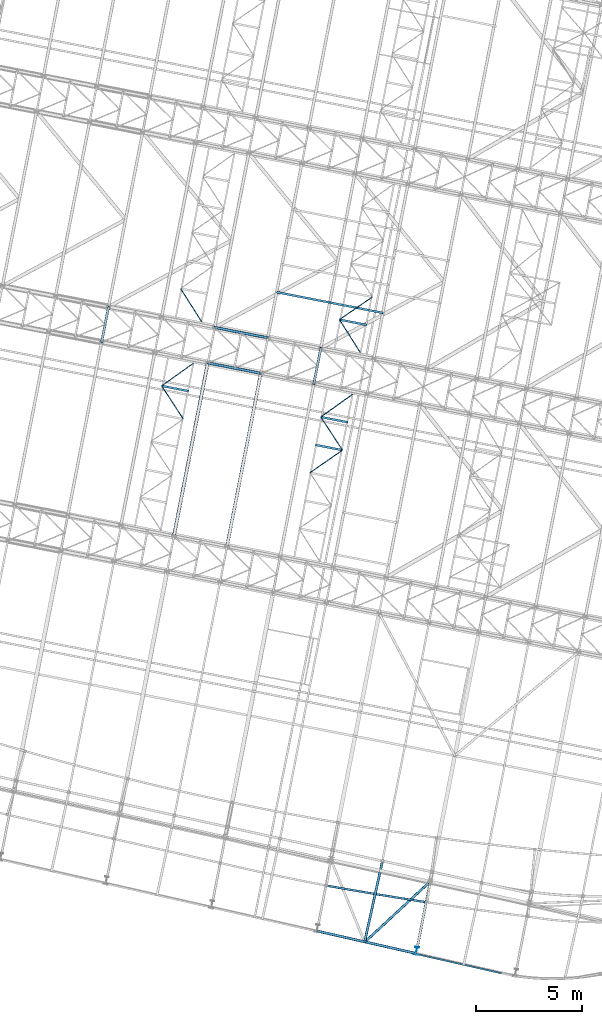
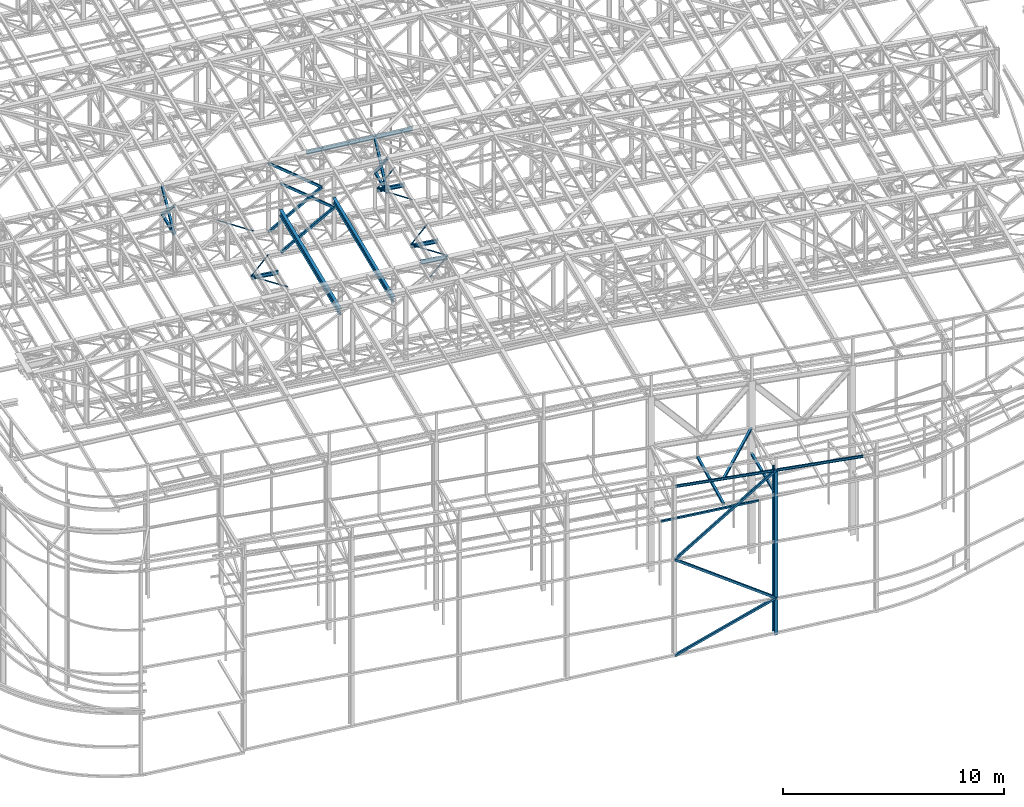
# One storey, part 45 of 215: 24 beams, 11 members, 35 elements without a shape of their own.
"""IFC2X3 building model written with IfcOpenShell, lengths in millimetres."""

import ifcopenshell
import ifcopenshell.guid

model = None  # the IFC model being written
_history = None  # IfcOwnerHistory: only IFC2X3 demands one
_inside = {}  # id of a spatial element -> (the spatial element, [elements in it])
_under = {}  # id of a project, library or spatial element -> (it, [spatial elements below it])
_declared = {}  # id of a project -> (the project, [libraries it declares])
_typed = {}  # id of a type object -> (the type object, [elements of that type])
_made_of = {}  # id of a material, layer set ... -> (it, [elements and type objects made of it])


def new_model(schema):
    """Start an empty IFC model of exactly this schema.

    Asked for "IFC4X3", IfcOpenShell would pick the latest addendum, in which some entities
    have other attributes; the version numbers below select the first issue.
    IFC2X3 requires an IfcOwnerHistory on every rooted entity: one is made here for all.
    """
    global model, _history
    if schema == "IFC4X3":
        model = ifcopenshell.file(schema_version=(4, 3, 0, 0))
    else:
        model = ifcopenshell.file(schema=schema)
    _inside.clear()
    _under.clear()
    _declared.clear()
    _typed.clear()
    _made_of.clear()
    _history = None
    if model.schema == "IFC2X3":
        org = make("IfcOrganization", Name="unknown")
        user = make(
            "IfcPersonAndOrganization",
            ThePerson=make("IfcPerson", FamilyName="unknown"),
            TheOrganization=org,
        )
        app = make(
            "IfcApplication",
            ApplicationDeveloper=org,
            Version="unknown",
            ApplicationFullName="unknown",
            ApplicationIdentifier="unknown",
        )
        _history = make(
            "IfcOwnerHistory",
            OwningUser=user,
            OwningApplication=app,
            ChangeAction="ADDED",
            CreationDate=0,
        )
    return model


def make(cls, **values):
    """One entity of the class cls with the attributes given. An attribute that is None is left unset."""
    return model.create_entity(
        cls, **{name: value for name, value in values.items() if value is not None}
    )


def entity(cls, *values):
    """Any entity or typed value of the class cls, its attributes in the order of the schema. None: left unset."""
    e = model.create_entity(cls)
    for i, value in enumerate(values):
        if value is not None:
            e[i] = value
    return e


def rooted(cls, **values):
    """An entity with a GlobalId (a new one), such as an element, a storey or a relation."""
    return make(cls, GlobalId=ifcopenshell.guid.new(), OwnerHistory=_history, **values)


def si_unit(unit_type, name, prefix=None):
    """IfcSIUnit, for example si_unit("LENGTHUNIT", "METRE", prefix="MILLI")."""
    return make("IfcSIUnit", UnitType=unit_type, Prefix=prefix, Name=name)


def assignment(units):
    """IfcUnitAssignment: the units of a project."""
    return None if units is None else make("IfcUnitAssignment", Units=units)


def point(xyz):
    """IfcCartesianPoint."""
    return None if xyz is None else make("IfcCartesianPoint", Coordinates=xyz)


def direction(xyz):
    """IfcDirection."""
    return None if xyz is None else make("IfcDirection", DirectionRatios=xyz)


def frame(location, z_axis=None, x_axis=None):
    """IfcAxis2Placement3D, a coordinate frame: its origin and axes. An axis left out is left unset."""
    return make(
        "IfcAxis2Placement3D",
        Location=point(location),
        Axis=direction(z_axis),
        RefDirection=direction(x_axis),
    )


def frame_2d(location, x_axis=None):
    """IfcAxis2Placement2D, a coordinate frame in the plane: its origin and x axis."""
    return make(
        "IfcAxis2Placement2D", Location=point(location), RefDirection=direction(x_axis)
    )


def origin_with_axes():
    """The frame at (0, 0, 0) with the z axis (0, 0, 1) and the x axis (1, 0, 0) written out."""
    return frame((0.0, 0.0, 0.0), z_axis=(0.0, 0.0, 1.0), x_axis=(1.0, 0.0, 0.0))


def origin_2d_with_axis():
    """The frame at (0, 0) in the plane with the x axis (1, 0) written out."""
    return frame_2d((0.0, 0.0), x_axis=(1.0, 0.0))


def place(relative_to, where):
    """IfcLocalPlacement: puts the frame where relative to a parent placement (None: the world)."""
    return make(
        "IfcLocalPlacement", PlacementRelTo=relative_to, RelativePlacement=where
    )


def context(
    kind, dimensions, precision=None, world=None, true_north=None, identifier=None
):
    """IfcGeometricRepresentationContext, for example the 3D "Model" context."""
    return make(
        "IfcGeometricRepresentationContext",
        ContextIdentifier=identifier,
        ContextType=kind,
        CoordinateSpaceDimension=dimensions,
        Precision=precision,
        WorldCoordinateSystem=world,
        TrueNorth=true_north,
    )


def subcontext(parent, identifier, kind, view, scale=None):
    """IfcGeometricRepresentationSubContext, for example "Body" below "Model"."""
    return make(
        "IfcGeometricRepresentationSubContext",
        ContextIdentifier=identifier,
        ContextType=kind,
        ParentContext=parent,
        TargetScale=scale,
        TargetView=view,
    )


def project(units=None, contexts=None):
    """IfcProject with its units and contexts."""
    return rooted(
        "IfcProject",
        Name="project",
        RepresentationContexts=contexts,
        UnitsInContext=assignment(units),
    )


def spatial(cls, under=None, at=None, **own):
    """A site, building, storey or space (cls), placed at a placement, below another one or the project."""
    s = rooted(cls, ObjectPlacement=at, **own)
    if under is not None:
        _under.setdefault(under.id(), (under, []))[1].append(s)
    return s


def profile(cls, at=None, kind="AREA", **sizes):
    """A parametric profile (cls). Its sizes go by their IFC names, for example OverallWidth=200.0."""
    return make(cls, ProfileType=kind, Position=at, **sizes)


def hollow_rectangle(**sizes):
    """IfcRectangleHollowProfileDef."""
    return profile("IfcRectangleHollowProfileDef", **sizes)


def i_section(**sizes):
    """IfcIShapeProfileDef."""
    return profile("IfcIShapeProfileDef", **sizes)


def extrude(swept, where, along, depth):
    """IfcExtrudedAreaSolid: the profile swept, set in the frame where, extruded along a direction by depth."""
    return make(
        "IfcExtrudedAreaSolid",
        SweptArea=swept,
        Position=where,
        ExtrudedDirection=direction(along),
        Depth=depth,
    )


def clip(a, b, op="DIFFERENCE"):
    """IfcBooleanClippingResult: the solid a cut by the half space b."""
    return make(
        "IfcBooleanClippingResult", Operator=op, FirstOperand=a, SecondOperand=b
    )


def halfspace(plane, agree):
    """IfcHalfSpaceSolid: all space on one side of the plane z = 0 of the frame plane."""
    return make(
        "IfcHalfSpaceSolid",
        BaseSurface=make("IfcPlane", Position=plane),
        AgreementFlag=agree,
    )


def shape(context_of_items, identifier, shape_type, items):
    """IfcShapeRepresentation: the items that make up one representation, for example the "Body"."""
    return make(
        "IfcShapeRepresentation",
        ContextOfItems=context_of_items,
        RepresentationIdentifier=identifier,
        RepresentationType=shape_type,
        Items=items,
    )


def material(Name=None, Category=None):
    """IfcMaterial."""
    return make("IfcMaterial", Name=Name, Category=Category)


def made_of(thing, what):
    """Note that an element or type object is made of a material, layer set ...; save() writes the relation."""
    if what is not None:
        _made_of.setdefault(what.id(), (what, []))[1].append(thing)
    return thing


def type_object(cls, material=None, **own):
    """A type object (cls), such as IfcWallType, which elements share."""
    return made_of(rooted(cls, **own), material)


def element(
    cls,
    number,
    at=None,
    inside=None,
    cuts=None,
    type_object=None,
    material=None,
    context=None,
    identifier="Body",
    shape_type=None,
    held_by="IfcProductDefinitionShape",
    body=None,
    shapes=None,
    **own,
):
    """One element of the class cls, such as IfcWall. Its Tag is "e" and its number.

    at: its placement. inside: the storey or other place that contains it. cuts: it is an
    opening in that element (IfcRelVoidsElement). A single representation is given by context,
    identifier, shape_type and body (its items); several are given by shapes. held_by: the class
    of the entity that holds the representations. save() writes the other relations.
    """
    e = rooted(cls, Tag="e%d" % number, ObjectPlacement=at, **own)
    if body is not None:
        shapes = [shape(context, identifier, shape_type, body)]
    if shapes is not None:
        e.Representation = make(held_by, Representations=shapes)
    if inside is not None:
        _inside.setdefault(inside.id(), (inside, []))[1].append(e)
    if cuts is not None:
        rooted(
            "IfcRelVoidsElement", RelatingBuildingElement=cuts, RelatedOpeningElement=e
        )
    if type_object is not None:
        _typed.setdefault(type_object.id(), (type_object, []))[1].append(e)
    return made_of(e, material)


def aggregate(whole, parts):
    """IfcRelAggregates: a whole, such as a stair, and the parts it consists of."""
    return rooted("IfcRelAggregates", RelatingObject=whole, RelatedObjects=parts)


def save(model, path):
    """Write the relations noted so far, then the file.

    IfcRelAggregates (storeys below a building ...), IfcRelContainedInSpatialStructure (elements
    in a storey), IfcRelDefinesByType, IfcRelAssociatesMaterial and IfcRelDeclares: one each for
    every whole, place, type object, material and project.
    """
    for whole, parts in _under.values():
        aggregate(whole, parts)
    for where, things in _inside.values():
        rooted(
            "IfcRelContainedInSpatialStructure",
            RelatedElements=things,
            RelatingStructure=where,
        )
    for kind, things in _typed.values():
        rooted("IfcRelDefinesByType", RelatedObjects=things, RelatingType=kind)
    for what, things in _made_of.values():
        rooted("IfcRelAssociatesMaterial", RelatedObjects=things, RelatingMaterial=what)
    for by, libraries in _declared.values():
        rooted("IfcRelDeclares", RelatingContext=by, RelatedDefinitions=libraries)
    model.write(path)


model = new_model("IFC2X3")

# Units and contexts
model_context = context("Model", 3, precision=1e-05, world=origin_with_axes())
body_context = subcontext(model_context, "Body", "Model", "MODEL_VIEW")
ifc_project = project(units=[si_unit("LENGTHUNIT", "METRE", prefix="MILLI"), si_unit("AREAUNIT", "SQUARE_METRE"), si_unit("VOLUMEUNIT", "CUBIC_METRE"), si_unit("MASSUNIT", "GRAM", prefix="KILO"), si_unit("TIMEUNIT", "SECOND"), si_unit("PLANEANGLEUNIT", "RADIAN"), si_unit("SOLIDANGLEUNIT", "STERADIAN"), si_unit("THERMODYNAMICTEMPERATUREUNIT", "DEGREE_CELSIUS"), si_unit("LUMINOUSINTENSITYUNIT", "LUMEN")], contexts=[model_context])

# Site, building, storey
site_placement = place(None, origin_with_axes())
site = spatial("IfcSite", under=ifc_project, at=site_placement, CompositionType="ELEMENT")
building_placement = place(site_placement, origin_with_axes())
building = spatial("IfcBuilding", under=site, at=building_placement, Name="Undefined", CompositionType="ELEMENT")
storey_placement = place(building_placement, origin_with_axes())
storey = spatial("IfcBuildingStorey", under=building, at=storey_placement, Name="Undefined", CompositionType="ELEMENT", Elevation=0.0)

# Assembly, beam
assembly_1_placement = place(storey_placement, origin_with_axes())
assembly_1 = element("IfcElementAssembly", 1, at=assembly_1_placement, inside=storey, Name="Steel Assembly", AssemblyPlace="NOTDEFINED", PredefinedType="RIGID_FRAME")
ifc_material = material(Name="STEEL/S275JR")
beam_type_1 = type_object("IfcBeamType", PredefinedType="NOTDEFINED")
beam_1_placement = place(assembly_1_placement, frame((64770.9839667064, 4600.98635841036, 6760.00000147687), z_axis=(0.163878451929886, 0.986480538577961, 0.0), x_axis=(0.986480538577961, -0.163878451929889, 0.0)))
beam_1 = element("IfcBeam", 2, at=beam_1_placement, type_object=beam_type_1, material=ifc_material, Name="POUTRE", context=body_context, shape_type="SweptSolid", body=[
    entity("IfcRevolvedAreaSolid", entity("IfcRectangleHollowProfileDef", "AREA", None, entity("IfcAxis2Placement2D", entity("IfcCartesianPoint", [0.0, 0.0]), entity("IfcDirection", [1.0, 0.0])), 100.0, 100.0, 4.0, 4.0, 8.0), entity("IfcAxis2Placement3D", entity("IfcCartesianPoint", [4704.21568529591, 1.81898940354586e-12, 0.0]), entity("IfcDirection", [-0.99993080787439, 0.0, -0.0117634800832606]), entity("IfcDirection", [-6.93889390390723e-18, -1.0, -3.46944695195361e-18])), entity("IfcAxis1Placement", entity("IfcCartesianPoint", [0.0, 199950.0, 0.0]), entity("IfcDirection", [-1.0, 0.0, 0.0])), 0.0235275028083408),
])
aggregate(assembly_1, [beam_1])

assembly_2_placement = place(storey_placement, origin_with_axes())
assembly_2 = element("IfcElementAssembly", 3, at=assembly_2_placement, inside=storey, Name="Steel Assembly", AssemblyPlace="NOTDEFINED", PredefinedType="RIGID_FRAME")
beam_type_2 = type_object("IfcBeamType", PredefinedType="NOTDEFINED")
beam_2_placement = place(assembly_2_placement, frame((54138.1134515478, 30177.5065873074, 10796.0000010585), z_axis=(0.981422364268518, -0.191859461052493, -0.000300197000082615), x_axis=(0.191859470081235, 0.981422408415534, 0.0)))
beam_2 = element("IfcBeam", 4, at=beam_2_placement, type_object=beam_type_2, material=ifc_material, context=body_context, shape_type="SweptSolid", body=[
    extrude(hollow_rectangle(XDim=120.0, YDim=120.0, WallThickness=5.0, InnerFilletRadius=5.0, OuterFilletRadius=10.0, at=origin_2d_with_axis()), frame((1699.99999941724, 1.81898940354586e-12, 0.0), z_axis=(-1.0, 0.0, 0.0), x_axis=(-6.93889390390723e-18, -1.0, -3.46944695195361e-18)), (0.0, 0.0, 1.0), 1700.0),
])
aggregate(assembly_2, [beam_2])

assembly_3_placement = place(storey_placement, origin_with_axes())
assembly_3 = element("IfcElementAssembly", 5, at=assembly_3_placement, inside=storey, Name="Steel Assembly", AssemblyPlace="NOTDEFINED", PredefinedType="RIGID_FRAME")
beam_3_placement = place(assembly_3_placement, frame((64123.006900931, 28225.5475660005, 10796.0000009293), z_axis=(0.981422364268518, -0.191859461052493, -0.000300197000082615), x_axis=(0.191859470081235, 0.981422408415534, 0.0)))
beam_3 = element("IfcBeam", 6, at=beam_3_placement, type_object=beam_type_2, material=ifc_material, context=body_context, shape_type="SweptSolid", body=[
    extrude(hollow_rectangle(XDim=120.0, YDim=120.0, WallThickness=5.0, InnerFilletRadius=5.0, OuterFilletRadius=10.0, at=origin_2d_with_axis()), frame((1699.99999941724, 1.81898940354586e-12, 0.0), z_axis=(-1.0, 0.0, 0.0), x_axis=(-6.93889390390723e-18, -1.0, -3.46944695195361e-18)), (0.0, 0.0, 1.0), 1700.0),
])
aggregate(assembly_3, [beam_3])

assembly_4_placement = place(storey_placement, origin_with_axes())
assembly_4 = element("IfcElementAssembly", 7, at=assembly_4_placement, inside=storey, Name="Steel Assembly", AssemblyPlace="NOTDEFINED", PredefinedType="RIGID_FRAME")
beam_4_placement = place(assembly_4_placement, frame((67336.8936056254, 5710.20351715289, 8706.00016661274), z_axis=(0.976594670308952, -0.215088005068043, 0.0), x_axis=(-0.215088005068044, -0.976594670308951, 0.0)))
beam_4 = element("IfcBeam", 8, at=beam_4_placement, type_object=beam_type_2, material=ifc_material, Name="LISSE", context=body_context, shape_type="SweptSolid", body=[
    extrude(hollow_rectangle(XDim=120.0, YDim=120.0, WallThickness=5.0, InnerFilletRadius=5.0, OuterFilletRadius=10.0, at=origin_2d_with_axis()), frame((3852.88180853571, 0.0, 0.0), z_axis=(-1.0, 0.0, 0.0), x_axis=(-6.93889390390723e-18, -1.0, -3.46944695195361e-18)), (0.0, 0.0, 1.0), 3852.9),
])
aggregate(assembly_4, [beam_4])

assembly_5_placement = place(storey_placement, origin_with_axes())
assembly_5 = element("IfcElementAssembly", 9, at=assembly_5_placement, inside=storey, Name="Steel Assembly", AssemblyPlace="NOTDEFINED", PredefinedType="RIGID_FRAME")
beam_5_placement = place(assembly_5_placement, frame((66507.7220365769, 1947.07164352828, 10126.061264413), z_axis=(-0.678909480736834, 0.734221980715398, 0.0), x_axis=(0.734181444701303, 0.678871998723806, -0.010507882995725)))
beam_5 = element("IfcBeam", 10, at=beam_5_placement, type_object=beam_type_2, material=ifc_material, context=body_context, shape_type="SweptSolid", body=[
    extrude(hollow_rectangle(XDim=120.0, YDim=120.0, WallThickness=5.0, InnerFilletRadius=5.0, OuterFilletRadius=10.0, at=origin_2d_with_axis()), frame((4201.79698825219, 0.0, -4.77933393639219e-13), z_axis=(-1.0, 0.0, 0.0), x_axis=(-6.93889390390723e-18, -1.0, -3.46944695195361e-18)), (0.0, 0.0, 1.0), 4201.8),
])
aggregate(assembly_5, [beam_5])

assembly_6_placement = place(storey_placement, origin_with_axes())
assembly_6 = element("IfcElementAssembly", 11, at=assembly_6_placement, inside=storey, Name="Steel Assembly", AssemblyPlace="NOTDEFINED", PredefinedType="RIGID_FRAME")
beam_6_placement = place(assembly_6_placement, frame((69593.9818501557, 4799.77453443794, 8710.00002362992), z_axis=(0.0, 0.0, 1.0), x_axis=(-0.191859508000518, -0.981422401002646, -1.00000033853845e-09)))
beam_6 = element("IfcBeam", 12, at=beam_6_placement, type_object=beam_type_2, material=ifc_material, Name="POUTRE", context=body_context, shape_type="SweptSolid", body=[
    extrude(hollow_rectangle(XDim=120.0, YDim=120.0, WallThickness=5.0, InnerFilletRadius=5.0, OuterFilletRadius=10.0, at=origin_2d_with_axis()), frame((3141.19587224381, 6.02668382536451e-16, 3.63797880644213e-12), z_axis=(-1.0, 0.0, 0.0), x_axis=(-6.93889390390723e-18, -1.0, -3.46944695195361e-18)), (0.0, 0.0, 1.0), 3141.2),
])
aggregate(assembly_6, [beam_6])

assembly_7_placement = place(storey_placement, origin_with_axes())
assembly_7 = element("IfcElementAssembly", 13, at=assembly_7_placement, inside=storey, Name="Steel Assembly", AssemblyPlace="NOTDEFINED", PredefinedType="RIGID_FRAME")
beam_type_3 = type_object("IfcBeamType", PredefinedType="NOTDEFINED")
beam_7_placement = place(assembly_7_placement, frame((57854.3678613469, 32698.2370776689, 8745.0), z_axis=(0.0, 0.0, -1.0), x_axis=(0.534709735290027, -0.84503579745835, 0.0)))
beam_7 = element("IfcBeam", 14, at=beam_7_placement, type_object=beam_type_3, material=ifc_material, context=body_context, shape_type="SweptSolid", body=[
    extrude(hollow_rectangle(XDim=50.0, YDim=50.0, WallThickness=3.0, InnerFilletRadius=3.0, OuterFilletRadius=6.0, at=origin_2d_with_axis()), frame((1837.43552283914, 1.01998161186009e-13, 0.0), z_axis=(-1.0, 0.0, 0.0), x_axis=(-6.93889390390723e-18, -1.0, -3.46944695195361e-18)), (0.0, 0.0, 1.0), 1837.4),
])
aggregate(assembly_7, [beam_7])

assembly_8_placement = place(storey_placement, origin_with_axes())
assembly_8 = element("IfcElementAssembly", 15, at=assembly_8_placement, inside=storey, Name="Steel Assembly", AssemblyPlace="NOTDEFINED", PredefinedType="RIGID_FRAME")
beam_8_placement = place(assembly_8_placement, frame((65326.6814343003, 31237.4655202843, 8745.0), z_axis=(0.0, 0.0, -1.0), x_axis=(0.534710843956443, -0.845035095931162, 0.0)))
beam_8 = element("IfcBeam", 16, at=beam_8_placement, type_object=beam_type_3, material=ifc_material, context=body_context, shape_type="SweptSolid", body=[
    extrude(hollow_rectangle(XDim=50.0, YDim=50.0, WallThickness=3.0, InnerFilletRadius=3.0, OuterFilletRadius=6.0, at=origin_2d_with_axis()), frame((1837.43336689014, 0.0, 0.0), z_axis=(-1.0, 0.0, 0.0), x_axis=(-6.93889390390723e-18, -1.0, -3.46944695195361e-18)), (0.0, 0.0, 1.0), 1837.4),
])
aggregate(assembly_8, [beam_8])

assembly_9_placement = place(storey_placement, origin_with_axes())
assembly_9 = element("IfcElementAssembly", 17, at=assembly_9_placement, inside=storey, Name="Steel Assembly", AssemblyPlace="NOTDEFINED", PredefinedType="RIGID_FRAME")
beam_9_placement = place(assembly_9_placement, frame((66878.0835303534, 32306.492479206, 8745.0), z_axis=(0.0, 0.0, -1.0), x_axis=(-0.823437347959834, -0.567407202972323, 0.0)))
beam_9 = element("IfcBeam", 18, at=beam_9_placement, type_object=beam_type_3, material=ifc_material, context=body_context, shape_type="SweptSolid", body=[
    extrude(hollow_rectangle(XDim=50.0, YDim=50.0, WallThickness=3.0, InnerFilletRadius=3.0, OuterFilletRadius=6.0, at=origin_2d_with_axis()), frame((1884.05602436896, 0.0, 0.0), z_axis=(-1.0, 0.0, 0.0), x_axis=(-6.93889390390723e-18, -1.0, -3.46944695195361e-18)), (0.0, 0.0, 1.0), 1884.1),
])
aggregate(assembly_9, [beam_9])

assembly_10_placement = place(storey_placement, origin_with_axes())
assembly_10 = element("IfcElementAssembly", 19, at=assembly_10_placement, inside=storey, Name="Steel Assembly", AssemblyPlace="NOTDEFINED", PredefinedType="RIGID_FRAME")
beam_10_placement = place(assembly_10_placement, frame((56963.2374973225, 28120.6013806335, 8745.0), z_axis=(0.0, 0.0, -1.0), x_axis=(0.545846908826853, -0.837884927734214, 0.0)))
beam_10 = element("IfcBeam", 20, at=beam_10_placement, type_object=beam_type_3, material=ifc_material, context=body_context, shape_type="SweptSolid", body=[
    extrude(hollow_rectangle(XDim=50.0, YDim=50.0, WallThickness=3.0, InnerFilletRadius=3.0, OuterFilletRadius=6.0, at=origin_2d_with_axis()), frame((1864.24701719659, 0.0, 0.0), z_axis=(-1.0, 0.0, 0.0), x_axis=(-6.93889390390723e-18, -1.0, -3.46944695195361e-18)), (0.0, 0.0, 1.0), 1864.2),
])
aggregate(assembly_10, [beam_10])

assembly_11_placement = place(storey_placement, origin_with_axes())
assembly_11 = element("IfcElementAssembly", 21, at=assembly_11_placement, inside=storey, Name="Steel Assembly", AssemblyPlace="NOTDEFINED", PredefinedType="RIGID_FRAME")
beam_11_placement = place(assembly_11_placement, frame((58453.4479776786, 29183.3123796387, 8745.0), z_axis=(0.0, 0.0, -1.0), x_axis=(-0.814179003918903, -0.580613941942168, 0.0)))
beam_11 = element("IfcBeam", 22, at=beam_11_placement, type_object=beam_type_3, material=ifc_material, context=body_context, shape_type="SweptSolid", body=[
    extrude(hollow_rectangle(XDim=50.0, YDim=50.0, WallThickness=3.0, InnerFilletRadius=3.0, OuterFilletRadius=6.0, at=origin_2d_with_axis()), frame((1830.3229068185, -1.81898940354586e-12, 0.0), z_axis=(-1.0, 0.0, 0.0), x_axis=(-6.93889390390723e-18, -1.0, -3.46944695195361e-18)), (0.0, 0.0, 1.0), 1830.3),
])
aggregate(assembly_11, [beam_11])

assembly_12_placement = place(storey_placement, origin_with_axes())
assembly_12 = element("IfcElementAssembly", 23, at=assembly_12_placement, inside=storey, Name="Steel Assembly", AssemblyPlace="NOTDEFINED", PredefinedType="RIGID_FRAME")
beam_12_placement = place(assembly_12_placement, frame((65468.507525145, 25095.5710707307, 8745.0), z_axis=(0.0, 0.0, -1.0), x_axis=(-0.821945876331178, -0.56956560322949, 0.0)))
beam_12 = element("IfcBeam", 24, at=beam_12_placement, type_object=beam_type_3, material=ifc_material, context=body_context, shape_type="SweptSolid", body=[
    extrude(hollow_rectangle(XDim=50.0, YDim=50.0, WallThickness=3.0, InnerFilletRadius=3.0, OuterFilletRadius=6.0, at=origin_2d_with_axis()), frame((1864.58536882556, 0.0, 0.0), z_axis=(-1.0, 0.0, 0.0), x_axis=(-6.93889390390723e-18, -1.0, -3.46944695195361e-18)), (0.0, 0.0, 1.0), 1864.6),
])
aggregate(assembly_12, [beam_12])

assembly_13_placement = place(storey_placement, origin_with_axes())
assembly_13 = element("IfcElementAssembly", 25, at=assembly_13_placement, inside=storey, Name="Steel Assembly", AssemblyPlace="NOTDEFINED", PredefinedType="RIGID_FRAME")
beam_13_placement = place(assembly_13_placement, frame((64449.5299488767, 26657.0970198296, 8745.0), z_axis=(0.0, 0.0, -1.0), x_axis=(0.546490170770853, -0.837465517648843, 0.0)))
beam_13 = element("IfcBeam", 26, at=beam_13_placement, type_object=beam_type_3, material=ifc_material, context=body_context, shape_type="SweptSolid", body=[
    extrude(hollow_rectangle(XDim=50.0, YDim=50.0, WallThickness=3.0, InnerFilletRadius=3.0, OuterFilletRadius=6.0, at=origin_2d_with_axis()), frame((1864.58536882556, 0.0, 0.0), z_axis=(-1.0, 0.0, 0.0), x_axis=(-6.93889390390723e-18, -1.0, -3.46944695195361e-18)), (0.0, 0.0, 1.0), 1864.6),
])
aggregate(assembly_13, [beam_13])

assembly_14_placement = place(storey_placement, origin_with_axes())
assembly_14 = element("IfcElementAssembly", 27, at=assembly_14_placement, inside=storey, Name="Steel Assembly", AssemblyPlace="NOTDEFINED", PredefinedType="RIGID_FRAME")
beam_14_placement = place(assembly_14_placement, frame((65940.269572781, 27722.6485136687, 8745.0), z_axis=(0.0, 0.0, -1.0), x_axis=(-0.813543072973564, -0.581504658981105, 0.0)))
beam_14 = element("IfcBeam", 28, at=beam_14_placement, type_object=beam_type_3, material=ifc_material, context=body_context, shape_type="SweptSolid", body=[
    extrude(hollow_rectangle(XDim=50.0, YDim=50.0, WallThickness=3.0, InnerFilletRadius=3.0, OuterFilletRadius=6.0, at=origin_2d_with_axis()), frame((1832.40405269771, 0.0, 0.0), z_axis=(-1.0, 0.0, 0.0), x_axis=(-6.93889390390723e-18, -1.0, -3.46944695195361e-18)), (0.0, 0.0, 1.0), 1832.4),
])
aggregate(assembly_14, [beam_14])

# Assembly, member
assembly_15_placement = place(storey_placement, origin_with_axes())
assembly_15 = element("IfcElementAssembly", 29, at=assembly_15_placement, inside=storey, Name="Steel Assembly", AssemblyPlace="NOTDEFINED", PredefinedType="RIGID_FRAME")
member_type = type_object("IfcMemberType", PredefinedType="NOTDEFINED")
member_1_placement = place(assembly_15_placement, frame((54464.2745502409, 31845.9246811296, 10796.0000010567), z_axis=(0.981461316285517, -0.191660209055757, 0.000221133000063429), x_axis=(-0.1413283100442, -0.722939399226104, 0.676302398211518)))
member_1 = element("IfcMember", 30, at=member_1_placement, type_object=member_type, material=ifc_material, context=body_context, shape_type="SweptSolid", body=[
    extrude(hollow_rectangle(XDim=120.0, YDim=120.0, WallThickness=5.0, InnerFilletRadius=5.0, OuterFilletRadius=10.0, at=origin_2d_with_axis()), frame((2307.82564529445, -1.28110058411315e-13, 8.31339197405457e-14), z_axis=(-1.0, 0.0, 0.0), x_axis=(-6.93889390390723e-18, -1.0, -3.46944695195361e-18)), (0.0, 0.0, 1.0), 2307.8),
])
aggregate(assembly_15, [member_1])

assembly_16_placement = place(storey_placement, origin_with_axes())
assembly_16 = element("IfcElementAssembly", 31, at=assembly_16_placement, inside=storey, Name="Steel Assembly", AssemblyPlace="NOTDEFINED", PredefinedType="RIGID_FRAME")
member_2_placement = place(assembly_16_placement, frame((54138.1134515478, 30177.5065873074, 10796.0000010585), z_axis=(0.981461316285734, -0.1916602090558, -0.000221132000064958), x_axis=(0.141328309922255, 0.722939402602315, 0.67630239462797)))
member_2 = element("IfcMember", 32, at=member_2_placement, type_object=member_type, material=ifc_material, context=body_context, shape_type="SweptSolid", body=[
    extrude(hollow_rectangle(XDim=120.0, YDim=120.0, WallThickness=5.0, InnerFilletRadius=5.0, OuterFilletRadius=10.0, at=origin_2d_with_axis()), frame((2307.82564529445, -1.28110058411315e-13, 8.31339197405457e-14), z_axis=(-1.0, 0.0, 0.0), x_axis=(-6.93889390390723e-18, -1.0, -3.46944695195361e-18)), (0.0, 0.0, 1.0), 2307.8),
])
aggregate(assembly_16, [member_2])

assembly_17_placement = place(storey_placement, origin_with_axes())
assembly_17 = element("IfcElementAssembly", 33, at=assembly_17_placement, inside=storey, Name="Steel Assembly", AssemblyPlace="NOTDEFINED", PredefinedType="RIGID_FRAME")
member_3_placement = place(assembly_17_placement, frame((64449.1679996097, 29893.9656598187, 10796.0000009276), z_axis=(0.981465045882622, -0.191641130977078, 0.000201564999975286), x_axis=(-0.128822807021333, -0.658969764109112, 0.741055689122704)))
member_3 = element("IfcMember", 34, at=member_3_placement, type_object=member_type, material=ifc_material, context=body_context, shape_type="SweptSolid", body=[
    extrude(hollow_rectangle(XDim=120.0, YDim=120.0, WallThickness=5.0, InnerFilletRadius=5.0, OuterFilletRadius=10.0, at=origin_2d_with_axis()), frame((2531.85832868423, -6.99486487302401e-12, 7.33099579250614e-12), z_axis=(-1.0, 0.0, 0.0), x_axis=(-6.93889390390723e-18, -1.0, -3.46944695195361e-18)), (0.0, 0.0, 1.0), 2531.9),
])
aggregate(assembly_17, [member_3])

assembly_18_placement = place(storey_placement, origin_with_axes())
assembly_18 = element("IfcElementAssembly", 35, at=assembly_18_placement, inside=storey, Name="Steel Assembly", AssemblyPlace="NOTDEFINED", PredefinedType="RIGID_FRAME")
member_4_placement = place(assembly_18_placement, frame((64123.006900931, 28225.5475660005, 10796.0000009293), z_axis=(0.981465045882622, -0.191641130977078, -0.000201564999975286), x_axis=(0.128822807951567, 0.658969767752257, 0.741055685721397)))
member_4 = element("IfcMember", 36, at=member_4_placement, type_object=member_type, material=ifc_material, context=body_context, shape_type="SweptSolid", body=[
    extrude(hollow_rectangle(XDim=120.0, YDim=120.0, WallThickness=5.0, InnerFilletRadius=5.0, OuterFilletRadius=10.0, at=origin_2d_with_axis()), frame((2531.85832868423, -6.99486487302401e-12, 7.33099579250614e-12), z_axis=(-1.0, 0.0, 0.0), x_axis=(-6.93889390390723e-18, -1.0, -3.46944695195361e-18)), (0.0, 0.0, 1.0), 2531.9),
])
aggregate(assembly_18, [member_4])

assembly_19_placement = place(storey_placement, origin_with_axes())
assembly_19 = element("IfcElementAssembly", 37, at=assembly_19_placement, inside=storey, Name="Steel Assembly", AssemblyPlace="NOTDEFINED", PredefinedType="RIGID_FRAME")
member_5_placement = place(assembly_19_placement, frame((64264.8028708501, 2473.30550828931, 830.135356955131), z_axis=(0.406286393042736, -0.0919650040096731, -0.90910604709562), x_axis=(0.886674670076416, -0.200703349017297, 0.416564755035901)))
member_5 = element("IfcMember", 38, at=member_5_placement, type_object=member_type, material=ifc_material, context=body_context, shape_type="SweptSolid", body=[
    extrude(hollow_rectangle(XDim=120.0, YDim=120.0, WallThickness=5.0, InnerFilletRadius=5.0, OuterFilletRadius=10.0, at=origin_2d_with_axis()), frame((5256.95590016355, 1.35745152562267e-13, 2.91819673990032e-13), z_axis=(-1.0, 0.0, 0.0), x_axis=(-6.93889390390723e-18, -1.0, -3.46944695195361e-18)), (0.0, 0.0, 1.0), 5257.0),
])
aggregate(assembly_19, [member_5])

assembly_20_placement = place(storey_placement, origin_with_axes())
assembly_20 = element("IfcElementAssembly", 39, at=assembly_20_placement, inside=storey, Name="Steel Assembly", AssemblyPlace="NOTDEFINED", PredefinedType="RIGID_FRAME")
member_6_placement = place(assembly_20_placement, frame((64266.5988506334, 2477.07855049049, 6117.50490590032), z_axis=(-0.530618710020068, 0.120217838004546, -0.839041987031729), x_axis=(0.818302683406362, -0.185397342092066, -0.544066672270178)))
member_6 = element("IfcMember", 40, at=member_6_placement, type_object=member_type, material=ifc_material, context=body_context, shape_type="SweptSolid", body=[
    extrude(hollow_rectangle(XDim=120.0, YDim=120.0, WallThickness=5.0, InnerFilletRadius=5.0, OuterFilletRadius=10.0, at=origin_2d_with_axis()), frame((5693.2489329677, 2.36365423294516e-14, 0.0), z_axis=(-1.0, 0.0, 0.0), x_axis=(-6.93889390390723e-18, -1.0, -3.46944695195361e-18)), (0.0, 0.0, 1.0), 5693.2),
])
aggregate(assembly_20, [member_6])

assembly_21_placement = place(storey_placement, origin_with_axes())
assembly_21 = element("IfcElementAssembly", 41, at=assembly_21_placement, inside=storey, Name="Steel Assembly", AssemblyPlace="NOTDEFINED", PredefinedType="RIGID_FRAME")
member_7_placement = place(assembly_21_placement, frame((68922.9146849711, 1422.12838068283, 10072.5096901134), z_axis=(0.622166583028296, -0.140960455006411, -0.770090185035026), x_axis=(-0.751055222077071, 0.170161532017461, -0.637935033065462)))
member_7 = element("IfcMember", 42, at=member_7_placement, type_object=member_type, material=ifc_material, context=body_context, shape_type="SweptSolid", body=[
    extrude(hollow_rectangle(XDim=120.0, YDim=120.0, WallThickness=5.0, InnerFilletRadius=5.0, OuterFilletRadius=10.0, at=origin_2d_with_axis()), frame((6199.69836780305, -6.57998925344639e-14, -7.96426240155002e-12), z_axis=(-1.0, 0.0, 0.0), x_axis=(-6.93889390390723e-18, -1.0, -3.46944695195361e-18)), (0.0, 0.0, 1.0), 6199.7),
])
aggregate(assembly_21, [member_7])

assembly_22_placement = place(storey_placement, origin_with_axes())
assembly_22 = element("IfcElementAssembly", 43, at=assembly_22_placement, inside=storey, Name="Steel Assembly", AssemblyPlace="NOTDEFINED", PredefinedType="RIGID_FRAME")
member_8_placement = place(assembly_22_placement, frame((59456.7224901458, 30869.9447932642, 8655.00000165958), z_axis=(0.587493472692391, -0.114849807939864, -0.801037415580578), x_axis=(0.786156070230782, -0.153686611045116, 0.598614282175727)))
member_8 = element("IfcMember", 44, at=member_8_placement, type_object=member_type, material=ifc_material, context=body_context, shape_type="SweptSolid", body=[
    extrude(hollow_rectangle(XDim=120.0, YDim=120.0, WallThickness=5.0, InnerFilletRadius=5.0, OuterFilletRadius=10.0, at=origin_2d_with_axis()), frame((3169.02675432624, -2.43384340210519e-14, 0.0), z_axis=(-1.0, 0.0, 0.0), x_axis=(-6.93889390390723e-18, -1.0, -3.46944695195361e-18)), (0.0, 0.0, 1.0), 3169.0),
])
aggregate(assembly_22, [member_8])

assembly_23_placement = place(storey_placement, origin_with_axes())
assembly_23 = element("IfcElementAssembly", 45, at=assembly_23_placement, inside=storey, Name="Steel Assembly", AssemblyPlace="NOTDEFINED", PredefinedType="RIGID_FRAME")
member_9_placement = place(assembly_23_placement, frame((59130.5614231802, 29201.526692592, 8655.00000165958), z_axis=(0.587493472692391, -0.114849807939864, -0.801037415580578), x_axis=(0.786156070230782, -0.153686611045116, 0.598614282175727)))
member_9 = element("IfcMember", 46, at=member_9_placement, type_object=member_type, material=ifc_material, context=body_context, shape_type="SweptSolid", body=[
    extrude(hollow_rectangle(XDim=120.0, YDim=120.0, WallThickness=5.0, InnerFilletRadius=5.0, OuterFilletRadius=10.0, at=origin_2d_with_axis()), frame((3169.02675432624, -2.43384340210519e-14, 0.0), z_axis=(-1.0, 0.0, 0.0), x_axis=(-6.93889390390723e-18, -1.0, -3.46944695195361e-18)), (0.0, 0.0, 1.0), 3169.0),
])
aggregate(assembly_23, [member_9])

assembly_24_placement = place(storey_placement, origin_with_axes())
assembly_24 = element("IfcElementAssembly", 47, at=assembly_24_placement, inside=storey, Name="Steel Assembly", AssemblyPlace="NOTDEFINED", PredefinedType="RIGID_FRAME")
member_10_placement = place(assembly_24_placement, frame((59461.4357356676, 30869.0233943679, 12449.5061705353), z_axis=(-0.588298020717598, 0.115007089944792, -0.800424142615768), x_axis=(0.785554192670352, -0.153568936935556, -0.599434059748455)))
member_10 = element("IfcMember", 48, at=member_10_placement, type_object=member_type, material=ifc_material, context=body_context, shape_type="SweptSolid", body=[
    extrude(hollow_rectangle(XDim=120.0, YDim=120.0, WallThickness=5.0, InnerFilletRadius=5.0, OuterFilletRadius=10.0, at=origin_2d_with_axis()), frame((3165.454916105, -7.21494952103048e-12, 7.45167566074706e-12), z_axis=(-1.0, 0.0, 0.0), x_axis=(-6.93889390390723e-18, -1.0, -3.46944695195361e-18)), (0.0, 0.0, 1.0), 3165.5),
])
aggregate(assembly_24, [member_10])

assembly_25_placement = place(storey_placement, origin_with_axes())
assembly_25 = element("IfcElementAssembly", 49, at=assembly_25_placement, inside=storey, Name="Steel Assembly", AssemblyPlace="NOTDEFINED", PredefinedType="RIGID_FRAME")
member_11_placement = place(assembly_25_placement, frame((59135.2746687167, 29200.6052936811, 12449.5061705353), z_axis=(-0.588298020717598, 0.115007089944792, -0.800424142615768), x_axis=(0.785554192670352, -0.153568936935556, -0.599434059748455)))
member_11 = element("IfcMember", 50, at=member_11_placement, type_object=member_type, material=ifc_material, context=body_context, shape_type="SweptSolid", body=[
    extrude(hollow_rectangle(XDim=120.0, YDim=120.0, WallThickness=5.0, InnerFilletRadius=5.0, OuterFilletRadius=10.0, at=origin_2d_with_axis()), frame((3165.454916105, -7.21494952103048e-12, 7.45167566074706e-12), z_axis=(-1.0, 0.0, 0.0), x_axis=(-6.93889390390723e-18, -1.0, -3.46944695195361e-18)), (0.0, 0.0, 1.0), 3165.5),
])
aggregate(assembly_25, [member_11])

# Assembly, beam
assembly_26_placement = place(storey_placement, origin_with_axes())
assembly_26 = element("IfcElementAssembly", 51, at=assembly_26_placement, inside=storey, Name="Steel Assembly", AssemblyPlace="NOTDEFINED", PredefinedType="RIGID_FRAME")
beam_type_4 = type_object("IfcBeamType", Name="IPE300", PredefinedType="NOTDEFINED")
beam_15_placement = place(assembly_26_placement, frame((60034.3552727476, 20567.7350149919, 10961.3100002071), z_axis=(0.0, 0.0, 1.0), x_axis=(0.191859470081235, 0.981422408415534, 0.0)))
beam_15 = element("IfcBeam", 52, at=beam_15_placement, type_object=beam_type_4, material=ifc_material, Name="SUPPORT", ObjectType="IPE300", context=body_context, shape_type="SweptSolid", body=[
    extrude(i_section(OverallWidth=150.0, OverallDepth=300.0, WebThickness=7.099999905, FlangeThickness=10.69999981, FilletRadius=15.0, at=origin_2d_with_axis()), frame((8299.99526300685, 1.47838788079098e-11, -1.71639879146031e-21), z_axis=(-1.0, 0.0, 0.0), x_axis=(-6.93889390390723e-18, -1.0, -3.46944695195361e-18)), (0.0, 0.0, 1.0), 8300.0),
])
aggregate(assembly_26, [beam_15])

assembly_27_placement = place(storey_placement, origin_with_axes())
assembly_27 = element("IfcElementAssembly", 53, at=assembly_27_placement, inside=storey, Name="Steel Assembly", AssemblyPlace="NOTDEFINED", PredefinedType="RIGID_FRAME")
beam_type_5 = type_object("IfcBeamType", Name="IPE360", PredefinedType="NOTDEFINED")
beam_16_placement = place(assembly_27_placement, frame((68950.9474706683, 1541.4184937314, 10135.4986660678), z_axis=(0.191859470081235, 0.981422408415534, 0.0), x_axis=(0.0, 0.0, -1.0)))
beam_16 = element("IfcBeam", 54, at=beam_16_placement, type_object=beam_type_5, material=ifc_material, Name="MONTANT", ObjectType="IPE360", context=body_context, shape_type="Clipping", body=[
    clip(extrude(i_section(OverallWidth=170.0, OverallDepth=360.0, WebThickness=8.0, FlangeThickness=12.69999981, FilletRadius=18.0, at=origin_2d_with_axis()), frame((9149.96628044183, 0.0, 0.0), z_axis=(-1.0, 0.0, 0.0), x_axis=(-6.93889390390723e-18, -1.0, -3.46944695195361e-18)), (0.0, 0.0, 1.0), 9150.0), halfspace(frame((9150.42211616252, 119.45663136417, -628.639192960514), z_axis=(-0.998850991769565, 0.0479026806605242, 0.0014245794090564), x_axis=(-1.0230287445127e-09, -0.0297259118404429, 0.999558087439271)), True)),
])
aggregate(assembly_27, [beam_16])

assembly_28_placement = place(storey_placement, origin_with_axes())
assembly_28 = element("IfcElementAssembly", 55, at=assembly_28_placement, inside=storey, Name="Steel Assembly", AssemblyPlace="NOTDEFINED", PredefinedType="RIGID_FRAME")
beam_type_6 = type_object("IfcBeamType", Name="IPE200", PredefinedType="NOTDEFINED")
beam_17_placement = place(assembly_28_placement, frame((62375.9739921236, 32529.6043206995, 11011.4879375182), z_axis=(0.0303605499861654, -0.00593522099729565, -0.99952139054462), x_axis=(0.980952689077156, -0.191767651015084, 0.030935252002433)))
beam_17 = element("IfcBeam", 56, at=beam_17_placement, type_object=beam_type_6, material=ifc_material, ObjectType="IPE200", context=body_context, shape_type="SweptSolid", body=[
    extrude(i_section(OverallWidth=100.0, OverallDepth=200.0, WebThickness=5.599999905, FlangeThickness=8.5, FilletRadius=12.0, at=origin_2d_with_axis()), frame((2544.66727454958, 2.95700928513306e-14, 1.81016081542643e-12), z_axis=(-1.0, 0.0, 0.0), x_axis=(-6.93889390390723e-18, -1.0, -3.46944695195361e-18)), (0.0, 0.0, 1.0), 2544.7),
])
aggregate(assembly_28, [beam_17])

assembly_29_placement = place(storey_placement, origin_with_axes())
assembly_29 = element("IfcElementAssembly", 57, at=assembly_29_placement, inside=storey, Name="Steel Assembly", AssemblyPlace="NOTDEFINED", PredefinedType="RIGID_FRAME")
beam_18_placement = place(assembly_29_placement, frame((64872.1974841796, 32041.611314076, 11090.3279375265), z_axis=(0.0303605499861654, -0.00593522099729565, -0.99952139054462), x_axis=(0.980952689077156, -0.191767651015084, 0.030935252002433)))
beam_18 = element("IfcBeam", 58, at=beam_18_placement, type_object=beam_type_6, material=ifc_material, ObjectType="IPE200", context=body_context, shape_type="SweptSolid", body=[
    extrude(i_section(OverallWidth=100.0, OverallDepth=200.0, WebThickness=5.599999905, FlangeThickness=8.5, FilletRadius=12.0, at=origin_2d_with_axis()), frame((2544.66727454958, 2.95700928513306e-14, 1.81016081542643e-12), z_axis=(-1.0, 0.0, 0.0), x_axis=(-6.93889390390723e-18, -1.0, -3.46944695195361e-18)), (0.0, 0.0, 1.0), 2544.7),
])
aggregate(assembly_29, [beam_18])

assembly_30_placement = place(storey_placement, origin_with_axes())
assembly_30 = element("IfcElementAssembly", 59, at=assembly_30_placement, inside=storey, Name="Steel Assembly", AssemblyPlace="NOTDEFINED", PredefinedType="RIGID_FRAME")
beam_19_placement = place(assembly_30_placement, frame((66615.2668435408, 30985.5153295846, 8670.00000000005), z_axis=(0.0, 0.0, -1.0), x_axis=(-0.98141623428027, 0.191891050054801, 0.0)))
beam_19 = element("IfcBeam", 60, at=beam_19_placement, type_object=beam_type_6, material=ifc_material, ObjectType="IPE200", context=body_context, shape_type="SweptSolid", body=[
    extrude(i_section(OverallWidth=100.0, OverallDepth=200.0, WebThickness=5.599999905, FlangeThickness=8.5, FilletRadius=12.0, at=origin_2d_with_axis()), frame((1312.98562652371, -3.64426718392127e-14, 0.0), z_axis=(-1.0, 0.0, 0.0), x_axis=(-6.93889390390723e-18, -1.0, -3.46944695195361e-18)), (0.0, 0.0, 1.0), 1313.0),
])
aggregate(assembly_30, [beam_19])

assembly_31_placement = place(storey_placement, origin_with_axes())
assembly_31 = element("IfcElementAssembly", 61, at=assembly_31_placement, inside=storey, Name="Steel Assembly", AssemblyPlace="NOTDEFINED", PredefinedType="RIGID_FRAME")
beam_20_placement = place(assembly_31_placement, frame((58239.0100072276, 27870.8221530314, 8670.00000000005), z_axis=(0.0, 0.0, -1.0), x_axis=(-0.981367778018941, 0.192138711003709, 0.0)))
beam_20 = element("IfcBeam", 62, at=beam_20_placement, type_object=beam_type_6, material=ifc_material, ObjectType="IPE200", context=body_context, shape_type="SweptSolid", body=[
    extrude(i_section(OverallWidth=100.0, OverallDepth=200.0, WebThickness=5.599999905, FlangeThickness=8.5, FilletRadius=12.0, at=origin_2d_with_axis()), frame((1299.99429213023, 0.0, -1.81898940354586e-12), z_axis=(-1.0, 0.0, 0.0), x_axis=(-6.93889390390723e-18, -1.0, -3.46944695195361e-18)), (0.0, 0.0, 1.0), 1300.0),
])
aggregate(assembly_31, [beam_20])

assembly_32_placement = place(storey_placement, origin_with_axes())
assembly_32 = element("IfcElementAssembly", 63, at=assembly_32_placement, inside=storey, Name="Steel Assembly", AssemblyPlace="NOTDEFINED", PredefinedType="RIGID_FRAME")
beam_21_placement = place(assembly_32_placement, frame((65725.3128646146, 26407.3358902246, 8670.00000000005), z_axis=(0.0, 0.0, -1.0), x_axis=(-0.981370698434766, 0.192123794085116, 0.0)))
beam_21 = element("IfcBeam", 64, at=beam_21_placement, type_object=beam_type_6, material=ifc_material, ObjectType="IPE200", context=body_context, shape_type="SweptSolid", body=[
    extrude(i_section(OverallWidth=100.0, OverallDepth=200.0, WebThickness=5.599999905, FlangeThickness=8.5, FilletRadius=12.0, at=origin_2d_with_axis()), frame((1300.00102692207, 3.60822768031308e-14, 0.0), z_axis=(-1.0, 0.0, 0.0), x_axis=(-6.93889390390723e-18, -1.0, -3.46944695195361e-18)), (0.0, 0.0, 1.0), 1300.0),
])
aggregate(assembly_32, [beam_21])

assembly_33_placement = place(storey_placement, origin_with_axes())
assembly_33 = element("IfcElementAssembly", 65, at=assembly_33_placement, inside=storey, Name="Steel Assembly", AssemblyPlace="NOTDEFINED", PredefinedType="RIGID_FRAME")
beam_22_placement = place(assembly_33_placement, frame((65468.507525145, 25095.5710707307, 8670.00000000005), z_axis=(0.0, 0.0, -1.0), x_axis=(-0.981370698434766, 0.192123794085116, 0.0)))
beam_22 = element("IfcBeam", 66, at=beam_22_placement, type_object=beam_type_6, material=ifc_material, ObjectType="IPE200", context=body_context, shape_type="SweptSolid", body=[
    extrude(i_section(OverallWidth=100.0, OverallDepth=200.0, WebThickness=5.599999905, FlangeThickness=8.5, FilletRadius=12.0, at=origin_2d_with_axis()), frame((1300.00102692207, 3.60822768031308e-14, 0.0), z_axis=(-1.0, 0.0, 0.0), x_axis=(-6.93889390390723e-18, -1.0, -3.46944695195361e-18)), (0.0, 0.0, 1.0), 1300.0),
])
aggregate(assembly_33, [beam_22])

assembly_34_placement = place(storey_placement, origin_with_axes())
assembly_34 = element("IfcElementAssembly", 67, at=assembly_34_placement, inside=storey, Name="Steel Assembly", AssemblyPlace="NOTDEFINED", PredefinedType="RIGID_FRAME")
beam_type_7 = type_object("IfcBeamType", Name="IPE140", PredefinedType="NOTDEFINED")
beam_23_placement = place(assembly_34_placement, frame((64261.7256760445, 2454.08472880671, 10161.9377512561), z_axis=(-0.0194763070031845, 0.00440106700072003, -0.999800632163619), x_axis=(0.97508489963513, -0.220931533917329, -0.0199673689925283)))
beam_23 = element("IfcBeam", 68, at=beam_23_placement, type_object=beam_type_7, material=ifc_material, Name="LISSE", ObjectType="IPE140", context=body_context, shape_type="SweptSolid", body=[
    extrude(i_section(OverallWidth=73.0, OverallDepth=140.0, WebThickness=4.699999809, FlangeThickness=6.900000095, FilletRadius=7.0, at=origin_2d_with_axis()), frame((8902.06647633148, -4.58874207828205e-13, 1.81898940354586e-12), z_axis=(-1.0, 0.0, 0.0), x_axis=(-6.93889390390723e-18, -1.0, -3.46944695195361e-18)), (0.0, 0.0, 1.0), 8902.1),
])
aggregate(assembly_34, [beam_23])

assembly_35_placement = place(storey_placement, origin_with_axes())
assembly_35 = element("IfcElementAssembly", 69, at=assembly_35_placement, inside=storey, Name="Steel Assembly", AssemblyPlace="NOTDEFINED", PredefinedType="RIGID_FRAME")
beam_type_8 = type_object("IfcBeamType", Name="IPE330", PredefinedType="NOTDEFINED")
beam_24_placement = place(assembly_35_placement, frame((57538.1311667161, 21055.7248758356, 10867.4700003382), z_axis=(0.0, 0.0, 1.0), x_axis=(0.191859470081235, 0.981422408415534, 0.0)))
beam_24 = element("IfcBeam", 70, at=beam_24_placement, type_object=beam_type_8, material=ifc_material, Name="SUPPORT", ObjectType="IPE330", context=body_context, shape_type="SweptSolid", body=[
    extrude(i_section(OverallWidth=160.0, OverallDepth=330.0, WebThickness=7.5, FlangeThickness=11.5, FilletRadius=18.0, at=origin_2d_with_axis()), frame((8299.99526300685, 1.47838788079098e-11, -1.71639879146031e-21), z_axis=(-1.0, 0.0, 0.0), x_axis=(-6.93889390390723e-18, -1.0, -3.46944695195361e-18)), (0.0, 0.0, 1.0), 8300.0),
])
aggregate(assembly_35, [beam_24])

save(model, "model.ifc")
